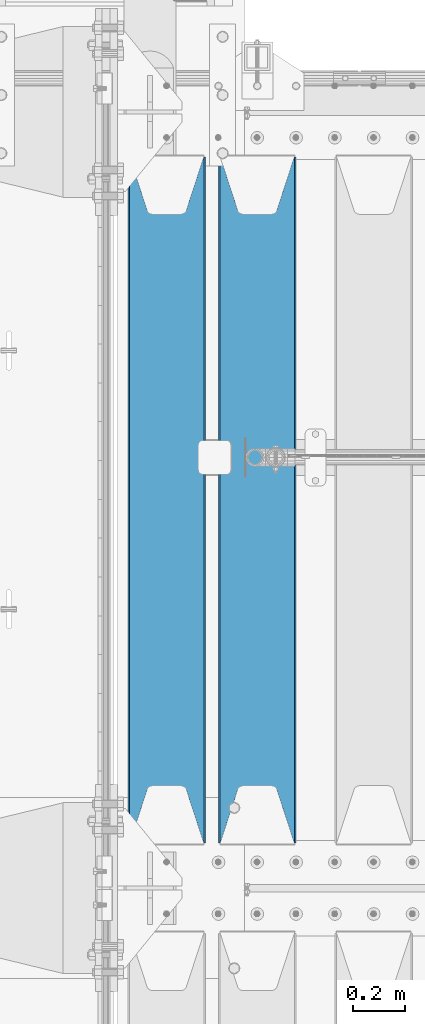
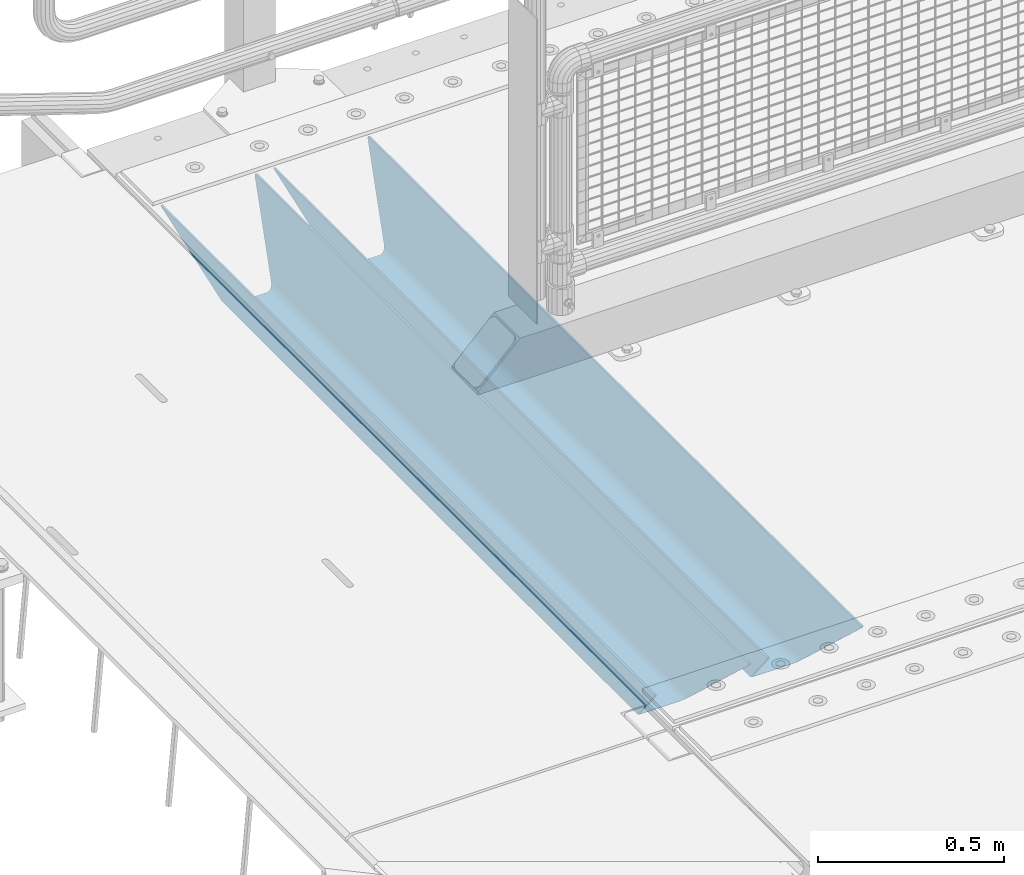
# One storey, part 108 of 219: 2 beams.
"""IFC2X3 building model written with IfcOpenShell, lengths in millimetres."""

from ifc_helpers import new_model, si_unit, frame, origin_with_axes, place, context, subcontext, project, spatial, faceted_brep, material, type_object, element, save


model = new_model("IFC2X3")

# Units and contexts
model_context = context("Model", 3, precision=1e-05, world=origin_with_axes())
body_context = subcontext(model_context, "Body", "Model", "MODEL_VIEW")
ifc_project = project(units=[si_unit("LENGTHUNIT", "METRE", prefix="MILLI"), si_unit("AREAUNIT", "SQUARE_METRE"), si_unit("VOLUMEUNIT", "CUBIC_METRE"), si_unit("MASSUNIT", "GRAM", prefix="KILO"), si_unit("TIMEUNIT", "SECOND"), si_unit("PLANEANGLEUNIT", "RADIAN"), si_unit("SOLIDANGLEUNIT", "STERADIAN"), si_unit("THERMODYNAMICTEMPERATUREUNIT", "DEGREE_CELSIUS"), si_unit("LUMINOUSINTENSITYUNIT", "LUMEN")], contexts=[model_context])

# Site, building, storey
site_placement = place(None, origin_with_axes())
site = spatial("IfcSite", under=ifc_project, at=site_placement, CompositionType="ELEMENT")
building_placement = place(site_placement, origin_with_axes())
building = spatial("IfcBuilding", under=site, at=building_placement, Name="Standard", CompositionType="ELEMENT")
storey_placement = place(building_placement, origin_with_axes())
storey = spatial("IfcBuildingStorey", under=building, at=storey_placement, Name="Undefined", CompositionType="ELEMENT", Elevation=0.0)

# Beams
ifc_material = material(Name="STEEL/S355N")
beam_type = type_object("IfcBeamType", PredefinedType="NOTDEFINED")
beam_1_placement = place(storey_placement, frame((550.0, 30175.0, -115.0), z_axis=(0.0, 0.0, 1.0), x_axis=(0.0, 1.0, 0.0)))
element("IfcBeam", 1, at=beam_1_placement, inside=storey, type_object=beam_type, material=ifc_material, context=body_context, shape_type="Brep", body=[
    faceted_brep([(0.0, 150.0, 115.0), (0.0, 143.690000000001, 115.0), (2650.00000000297, 143.690000000001, 115.0), (2650.00000000297, 150.0, 115.0), (2650.00000000297, 142.0595652184, 110.000000003094), (2650.00000000297, 148.3695652184, 110.000000003094), (2441.90079219209, -80.110360073113, -98.0992078077845), (2437.7588105432, -77.5672621345566, -102.241189456673), (2434.06523489747, -74.4080125315541, -105.934765102404), (2430.9108609509, -70.7102721255742, -109.089139048974), (2428.37322971128, -66.5649389910068, -111.626770288588), (2426.51472138055, -62.0739139532889, -113.485278619323), (2425.38102192092, -57.3475956567672, -114.618978078955), (2424.99999999988, -52.5021667386536, -115.0), (2424.99999999988, 52.5021667386536, -115.0), (2425.38102192092, 57.3475956567672, -114.618978078955), (2426.51472138055, 62.0739139532889, -113.485278619323), (2428.37322971128, 66.5649389910068, -111.626770288588), (2430.9108609509, 70.7102721255742, -109.089139048974), (2434.06523489747, 74.4080125315541, -105.934765102404), (2437.7588105432, 77.5672621345566, -102.241189456673), (2441.90079219209, 80.110360073113, -98.0992078077846), (2446.38936140512, 81.9747917625791, -93.6106385947584), (2448.2494850041, 76.2713538057269, -91.7505149957729), (2444.62967112263, 74.7677798626082, -95.3703288772456), (2441.28936334127, 72.7168944282894, -98.710636658607), (2438.31067330439, 70.1691124903828, -101.689326695487), (2435.76682334748, 67.1870637758839, -104.233176652398), (2433.72034654134, 63.8440531834913, -106.279653458539), (2432.22154950042, 60.2222587982342, -107.778450499454), (2431.30727574265, 56.4107117849107, -108.692724257221), (2430.99999999987, 52.5031078186894, -109.0), (2430.99999999987, -52.5031078186894, -109.0), (2431.30727574265, -56.4107117849107, -108.692724257221), (2432.22154950042, -60.2222587982342, -107.778450499454), (2433.72034654134, -63.8440531834913, -106.279653458539), (2435.76682334748, -67.1870637758839, -104.233176652398), (2438.31067330439, -70.1691124903828, -101.689326695487), (2441.28936334127, -72.7168944282894, -98.7106366586071), (2444.62967112263, -74.7677798626082, -95.3703288772457), (2448.2494850041, -76.2713538057269, -91.7505149957729), (2650.00000000297, -142.0595652184, 110.000000003094), (2650.00000000297, -148.3695652184, 110.000000003094), (2446.38936140512, -81.9747917625791, -93.6106385947584), (2650.00000000297, -143.690000000001, 115.0), (2650.00000000297, -150.0, 115.0), (0.0, -143.690000000001, 115.0), (0.0, -150.0, 115.0), (0.0, -148.369565218261, 110.000000002667), (203.610638597427, -81.9747917625791, -93.6106385947584), (208.09920781045, -80.110360073113, -98.0992078077845), (212.241189459342, -77.5672621345566, -102.241189456673), (215.93476510507, -74.4080125315541, -105.934765102404), (219.089139051641, -70.7102721255742, -109.089139048974), (221.626770291256, -66.5649389910068, -111.626770288588), (223.485278621989, -62.0739139532889, -113.485278619323), (224.618978081624, -57.3475956567672, -114.618978078955), (225.000000002663, -52.5021667386536, -115.0), (225.000000002663, 52.5021667386536, -115.0), (224.618978081624, 57.3475956567672, -114.618978078955), (223.485278621989, 62.0739139532889, -113.485278619323), (221.626770291256, 66.5649389910068, -111.626770288588), (219.089139051641, 70.7102721255742, -109.089139048974), (215.93476510507, 74.4080125315541, -105.934765102404), (212.241189459342, 77.5672621345566, -102.241189456673), (208.09920781045, 80.110360073113, -98.0992078077846), (203.610638597427, 81.9747917625791, -93.6106385947584), (0.0, 148.369565218261, 110.000000002667), (0.0, 142.059565218262, 110.000000002667), (201.750514998439, 76.2713538057269, -91.7505149957729), (205.370328879915, 74.7677798626082, -95.3703288772456), (208.710636661275, 72.7168944282894, -98.710636658607), (211.689326698157, 70.1691124903828, -101.689326695487), (214.233176655063, 67.1870637758839, -104.233176652398), (216.279653461206, 63.8440531834913, -106.279653458539), (217.778450502123, 60.2222587982342, -107.778450499454), (218.69272425989, 56.4107117849107, -108.692724257221), (219.00000000267, 52.5031078186894, -109.0), (219.00000000267, -52.5031078186894, -109.0), (218.69272425989, -56.4107117849107, -108.692724257221), (217.778450502123, -60.2222587982342, -107.778450499454), (216.279653461206, -63.8440531834913, -106.279653458539), (214.233176655063, -67.1870637758839, -104.233176652398), (211.689326698157, -70.1691124903828, -101.689326695487), (208.710636661275, -72.7168944282894, -98.7106366586071), (205.370328879915, -74.7677798626082, -95.3703288772457), (201.750514998439, -76.2713538057269, -91.7505149957729), (0.0, -142.059565218262, 110.000000002667)], [[[0, 1, 2, 3]], [[3, 2, 4, 5]], [[6, 7, 8, 9, 10, 11, 12, 13, 14, 15, 16, 17, 18, 19, 20, 21, 22, 5, 4, 23, 24, 25, 26, 27, 28, 29, 30, 31, 32, 33, 34, 35, 36, 37, 38, 39, 40, 41, 42, 43]], [[44, 45, 42, 41]], [[46, 47, 45, 44]], [[43, 42, 45, 47, 48, 49]], [[6, 43, 49, 50]], [[7, 6, 50, 51]], [[8, 7, 51, 52]], [[9, 8, 52, 53]], [[10, 9, 53, 54]], [[11, 10, 54, 55]], [[12, 11, 55, 56]], [[13, 12, 56, 57]], [[14, 13, 57, 58]], [[15, 14, 58, 59]], [[16, 15, 59, 60]], [[17, 16, 60, 61]], [[18, 17, 61, 62]], [[19, 18, 62, 63]], [[20, 19, 63, 64]], [[21, 20, 64, 65]], [[22, 21, 65, 66]], [[0, 3, 5, 22, 66, 67]], [[1, 0, 67, 68]], [[23, 4, 2, 1, 68, 69]], [[24, 23, 69, 70]], [[25, 24, 70, 71]], [[26, 25, 71, 72]], [[27, 26, 72, 73]], [[28, 27, 73, 74]], [[29, 28, 74, 75]], [[30, 29, 75, 76]], [[31, 30, 76, 77]], [[32, 31, 77, 78]], [[33, 32, 78, 79]], [[34, 33, 79, 80]], [[35, 34, 80, 81]], [[36, 35, 81, 82]], [[37, 36, 82, 83]], [[38, 37, 83, 84]], [[39, 38, 84, 85]], [[40, 39, 85, 86]], [[46, 44, 41, 40, 86, 87]], [[47, 46, 87, 48]], [[86, 85, 84, 83, 82, 81, 80, 79, 78, 77, 76, 75, 74, 73, 72, 71, 70, 69, 68, 67, 66, 65, 64, 63, 62, 61, 60, 59, 58, 57, 56, 55, 54, 53, 52, 51, 50, 49, 48, 87]]]),
])
beam_2_placement = place(storey_placement, frame((200.0, 30175.0, -115.0), z_axis=(0.0, 0.0, 1.0), x_axis=(0.0, 1.0, 0.0)))
element("IfcBeam", 2, at=beam_2_placement, inside=storey, type_object=beam_type, material=ifc_material, context=body_context, shape_type="Brep", body=[
    faceted_brep([(0.0, 150.0, 115.0), (0.0, 143.690000000001, 115.0), (2650.00000000297, 143.690000000001, 115.0), (2650.00000000297, 150.0, 115.0), (2650.00000000297, 142.0595652184, 110.000000003094), (2650.00000000297, 148.3695652184, 110.000000003094), (2441.90079219209, -80.110360073113, -98.0992078077845), (2437.7588105432, -77.5672621345566, -102.241189456673), (2434.06523489747, -74.4080125315541, -105.934765102404), (2430.9108609509, -70.7102721255742, -109.089139048974), (2428.37322971128, -66.5649389910068, -111.626770288588), (2426.51472138055, -62.0739139532889, -113.485278619323), (2425.38102192092, -57.3475956567672, -114.618978078955), (2424.99999999988, -52.5021667386536, -115.0), (2424.99999999988, 52.5021667386536, -115.0), (2425.38102192092, 57.3475956567672, -114.618978078955), (2426.51472138055, 62.0739139532889, -113.485278619323), (2428.37322971128, 66.5649389910068, -111.626770288588), (2430.9108609509, 70.7102721255742, -109.089139048974), (2434.06523489747, 74.4080125315541, -105.934765102404), (2437.7588105432, 77.5672621345566, -102.241189456673), (2441.90079219209, 80.110360073113, -98.0992078077846), (2446.38936140512, 81.9747917625791, -93.6106385947584), (2448.2494850041, 76.2713538057269, -91.7505149957729), (2444.62967112263, 74.7677798626082, -95.3703288772456), (2441.28936334127, 72.7168944282894, -98.710636658607), (2438.31067330439, 70.1691124903828, -101.689326695487), (2435.76682334748, 67.1870637758839, -104.233176652398), (2433.72034654134, 63.8440531834913, -106.279653458539), (2432.22154950042, 60.2222587982342, -107.778450499454), (2431.30727574265, 56.4107117849107, -108.692724257221), (2430.99999999987, 52.5031078186894, -109.0), (2430.99999999987, -52.5031078186894, -109.0), (2431.30727574265, -56.4107117849107, -108.692724257221), (2432.22154950042, -60.2222587982342, -107.778450499454), (2433.72034654134, -63.8440531834913, -106.279653458539), (2435.76682334748, -67.1870637758839, -104.233176652398), (2438.31067330439, -70.1691124903828, -101.689326695487), (2441.28936334127, -72.7168944282894, -98.7106366586071), (2444.62967112263, -74.7677798626082, -95.3703288772457), (2448.2494850041, -76.2713538057269, -91.7505149957729), (2650.00000000297, -142.0595652184, 110.000000003094), (2650.00000000297, -148.3695652184, 110.000000003094), (2446.38936140512, -81.9747917625791, -93.6106385947584), (2650.00000000297, -143.690000000001, 115.0), (2650.00000000297, -150.0, 115.0), (0.0, -143.690000000001, 115.0), (0.0, -150.0, 115.0), (0.0, -148.369565218261, 110.000000002667), (203.610638597427, -81.9747917625791, -93.6106385947584), (208.09920781045, -80.110360073113, -98.0992078077845), (212.241189459342, -77.5672621345566, -102.241189456673), (215.93476510507, -74.4080125315541, -105.934765102404), (219.089139051641, -70.7102721255742, -109.089139048974), (221.626770291256, -66.5649389910068, -111.626770288588), (223.485278621989, -62.0739139532889, -113.485278619323), (224.618978081624, -57.3475956567672, -114.618978078955), (225.000000002663, -52.5021667386536, -115.0), (225.000000002663, 52.5021667386536, -115.0), (224.618978081624, 57.3475956567672, -114.618978078955), (223.485278621989, 62.0739139532889, -113.485278619323), (221.626770291256, 66.5649389910068, -111.626770288588), (219.089139051641, 70.7102721255742, -109.089139048974), (215.93476510507, 74.4080125315541, -105.934765102404), (212.241189459342, 77.5672621345566, -102.241189456673), (208.09920781045, 80.110360073113, -98.0992078077846), (203.610638597427, 81.9747917625791, -93.6106385947584), (0.0, 148.369565218261, 110.000000002667), (0.0, 142.059565218262, 110.000000002667), (201.750514998439, 76.2713538057269, -91.7505149957729), (205.370328879915, 74.7677798626082, -95.3703288772456), (208.710636661275, 72.7168944282894, -98.710636658607), (211.689326698157, 70.1691124903828, -101.689326695487), (214.233176655063, 67.1870637758839, -104.233176652398), (216.279653461206, 63.8440531834913, -106.279653458539), (217.778450502123, 60.2222587982342, -107.778450499454), (218.69272425989, 56.4107117849107, -108.692724257221), (219.00000000267, 52.5031078186894, -109.0), (219.00000000267, -52.5031078186894, -109.0), (218.69272425989, -56.4107117849107, -108.692724257221), (217.778450502123, -60.2222587982342, -107.778450499454), (216.279653461206, -63.8440531834913, -106.279653458539), (214.233176655063, -67.1870637758839, -104.233176652398), (211.689326698157, -70.1691124903828, -101.689326695487), (208.710636661275, -72.7168944282894, -98.7106366586071), (205.370328879915, -74.7677798626082, -95.3703288772457), (201.750514998439, -76.2713538057269, -91.7505149957729), (0.0, -142.059565218262, 110.000000002667)], [[[0, 1, 2, 3]], [[3, 2, 4, 5]], [[6, 7, 8, 9, 10, 11, 12, 13, 14, 15, 16, 17, 18, 19, 20, 21, 22, 5, 4, 23, 24, 25, 26, 27, 28, 29, 30, 31, 32, 33, 34, 35, 36, 37, 38, 39, 40, 41, 42, 43]], [[44, 45, 42, 41]], [[46, 47, 45, 44]], [[43, 42, 45, 47, 48, 49]], [[6, 43, 49, 50]], [[7, 6, 50, 51]], [[8, 7, 51, 52]], [[9, 8, 52, 53]], [[10, 9, 53, 54]], [[11, 10, 54, 55]], [[12, 11, 55, 56]], [[13, 12, 56, 57]], [[14, 13, 57, 58]], [[15, 14, 58, 59]], [[16, 15, 59, 60]], [[17, 16, 60, 61]], [[18, 17, 61, 62]], [[19, 18, 62, 63]], [[20, 19, 63, 64]], [[21, 20, 64, 65]], [[22, 21, 65, 66]], [[0, 3, 5, 22, 66, 67]], [[1, 0, 67, 68]], [[23, 4, 2, 1, 68, 69]], [[24, 23, 69, 70]], [[25, 24, 70, 71]], [[26, 25, 71, 72]], [[27, 26, 72, 73]], [[28, 27, 73, 74]], [[29, 28, 74, 75]], [[30, 29, 75, 76]], [[31, 30, 76, 77]], [[32, 31, 77, 78]], [[33, 32, 78, 79]], [[34, 33, 79, 80]], [[35, 34, 80, 81]], [[36, 35, 81, 82]], [[37, 36, 82, 83]], [[38, 37, 83, 84]], [[39, 38, 84, 85]], [[40, 39, 85, 86]], [[46, 44, 41, 40, 86, 87]], [[47, 46, 87, 48]], [[86, 85, 84, 83, 82, 81, 80, 79, 78, 77, 76, 75, 74, 73, 72, 71, 70, 69, 68, 67, 66, 65, 64, 63, 62, 61, 60, 59, 58, 57, 56, 55, 54, 53, 52, 51, 50, 49, 48, 87]]]),
])

save(model, "model.ifc")
